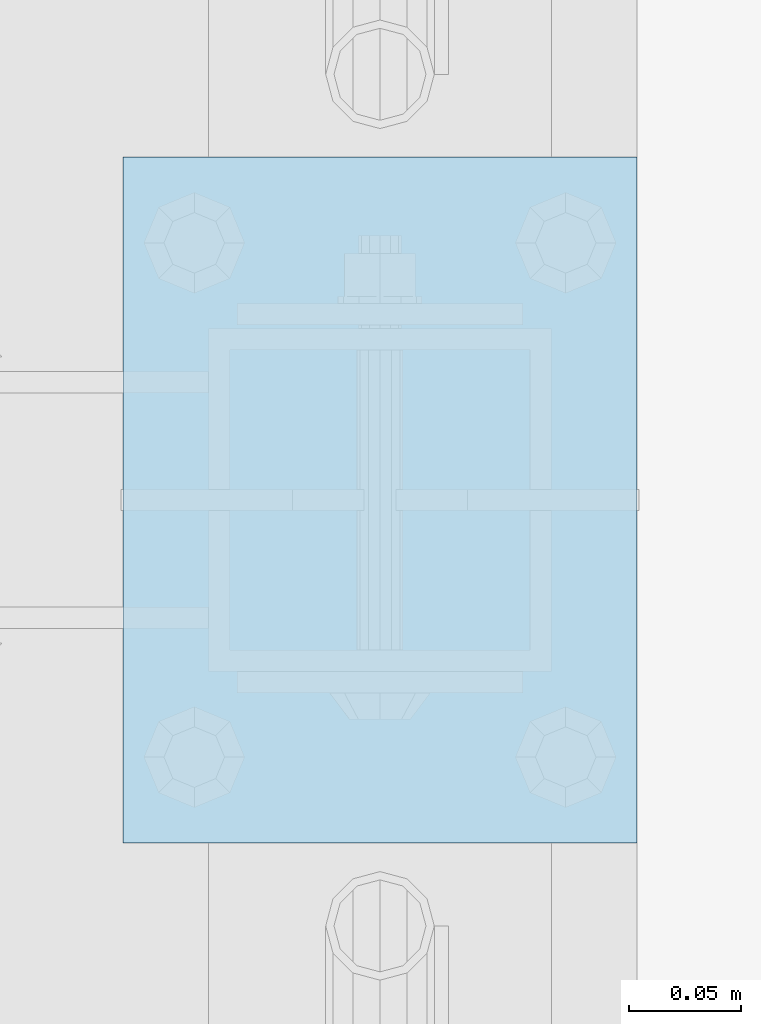
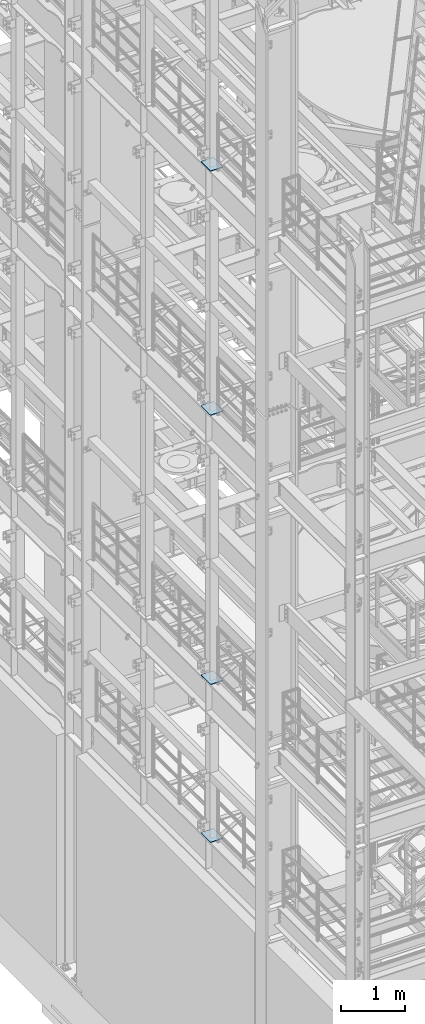
# One storey, part 1481 of 1876: 4 plates, 4 elements without a shape of their own.
"""IFC2X3 building model written with IfcOpenShell, lengths in millimetres."""

from ifc_helpers import new_model, si_unit, frame, origin_with_axes, place, context, subcontext, project, spatial, faceted_brep, material, type_object, element, aggregate, save


model = new_model("IFC2X3")

# Units and contexts
model_context = context("Model", 3, precision=1e-05, world=origin_with_axes())
body_context = subcontext(model_context, "Body", "Model", "MODEL_VIEW")
ifc_project = project(units=[si_unit("LENGTHUNIT", "METRE", prefix="MILLI"), si_unit("AREAUNIT", "SQUARE_METRE"), si_unit("VOLUMEUNIT", "CUBIC_METRE"), si_unit("MASSUNIT", "GRAM", prefix="KILO"), si_unit("TIMEUNIT", "SECOND"), si_unit("PLANEANGLEUNIT", "RADIAN"), si_unit("SOLIDANGLEUNIT", "STERADIAN"), si_unit("THERMODYNAMICTEMPERATUREUNIT", "DEGREE_CELSIUS"), si_unit("LUMINOUSINTENSITYUNIT", "LUMEN")], contexts=[model_context])

# Site, building, storey
site_placement = place(None, origin_with_axes())
site = spatial("IfcSite", under=ifc_project, at=site_placement, CompositionType="ELEMENT")
building_placement = place(site_placement, origin_with_axes())
building = spatial("IfcBuilding", under=site, at=building_placement, Name="Undefined", CompositionType="ELEMENT")
storey_placement = place(building_placement, origin_with_axes())
storey = spatial("IfcBuildingStorey", under=building, at=storey_placement, Name="Undefined", CompositionType="ELEMENT", Elevation=0.0)

# Assembly, plate
assembly_1_placement = place(storey_placement, origin_with_axes())
assembly_1 = element("IfcElementAssembly", 1, at=assembly_1_placement, inside=storey, Name="BEAM", AssemblyPlace="NOTDEFINED", PredefinedType="RIGID_FRAME")
ifc_material = material(Name="STEEL/A36")
plate_type = type_object("IfcPlateType", PredefinedType="NOTDEFINED")
plate_1_placement = place(assembly_1_placement, frame((-114.3, -2692.4, 17989.55), z_axis=(0.0, 1.0, 0.0), x_axis=(1.0, 0.0, 0.0)))
plate_1 = element("IfcPlate", 2, at=plate_1_placement, type_object=plate_type, material=ifc_material, Name="PLATE", context=body_context, shape_type="Brep", body=[
    faceted_brep([(0.0, -6.35000000000036, 0.0), (0.0, -6.35000000000036, 304.799987792969), (0.0, 6.35000000000036, 304.799987792969), (0.0, 6.35000000000036, 0.0), (228.600006103516, -6.34999999999854, 304.799987792969), (228.600006103516, 6.34999999999854, 304.799987792969), (228.600006103516, -6.34999999999854, 0.0), (228.600006103516, 6.34999999999854, 0.0)], [[[0, 1, 2, 3]], [[1, 4, 5, 2]], [[4, 6, 7, 5]], [[6, 0, 3, 7]], [[5, 7, 3, 2]], [[6, 4, 1, 0]]]),
])
aggregate(assembly_1, [plate_1])

assembly_2_placement = place(storey_placement, origin_with_axes())
assembly_2 = element("IfcElementAssembly", 3, at=assembly_2_placement, inside=storey, Name="BEAM", AssemblyPlace="NOTDEFINED", PredefinedType="RIGID_FRAME")
plate_2_placement = place(assembly_2_placement, frame((-114.3, -2692.4, 13315.95), z_axis=(0.0, 1.0, 0.0), x_axis=(1.0, 0.0, 0.0)))
plate_2 = element("IfcPlate", 4, at=plate_2_placement, type_object=plate_type, material=ifc_material, Name="PLATE", context=body_context, shape_type="Brep", body=[
    faceted_brep([(0.0, -6.35000000000036, 0.0), (0.0, -6.35000000000036, 304.799987792969), (0.0, 6.35000000000036, 304.799987792969), (0.0, 6.35000000000036, 0.0), (228.600006103516, -6.34999999999854, 304.799987792969), (228.600006103516, 6.34999999999854, 304.799987792969), (228.600006103516, -6.34999999999854, 0.0), (228.600006103516, 6.34999999999854, 0.0)], [[[0, 1, 2, 3]], [[1, 4, 5, 2]], [[4, 6, 7, 5]], [[6, 0, 3, 7]], [[5, 7, 3, 2]], [[6, 4, 1, 0]]]),
])
aggregate(assembly_2, [plate_2])

assembly_3_placement = place(storey_placement, origin_with_axes())
assembly_3 = element("IfcElementAssembly", 5, at=assembly_3_placement, inside=storey, Name="BEAM", AssemblyPlace="NOTDEFINED", PredefinedType="RIGID_FRAME")
plate_3_placement = place(assembly_3_placement, frame((-114.3, -2692.4, 8159.75), z_axis=(0.0, 1.0, 0.0), x_axis=(1.0, 0.0, 0.0)))
plate_3 = element("IfcPlate", 6, at=plate_3_placement, type_object=plate_type, material=ifc_material, Name="PLATE", context=body_context, shape_type="Brep", body=[
    faceted_brep([(0.0, -6.35000000000036, 0.0), (0.0, -6.35000000000036, 304.799987792969), (0.0, 6.35000000000036, 304.799987792969), (0.0, 6.35000000000036, 0.0), (228.600006103516, -6.34999999999854, 304.799987792969), (228.600006103516, 6.34999999999854, 304.799987792969), (228.600006103516, -6.34999999999854, 0.0), (228.600006103516, 6.34999999999854, 0.0)], [[[0, 1, 2, 3]], [[1, 4, 5, 2]], [[4, 6, 7, 5]], [[6, 0, 3, 7]], [[5, 7, 3, 2]], [[6, 4, 1, 0]]]),
])
aggregate(assembly_3, [plate_3])

assembly_4_placement = place(storey_placement, origin_with_axes())
assembly_4 = element("IfcElementAssembly", 7, at=assembly_4_placement, inside=storey, Name="BEAM", AssemblyPlace="NOTDEFINED", PredefinedType="RIGID_FRAME")
plate_4_placement = place(assembly_4_placement, frame((-114.3, -2692.4, 5137.15), z_axis=(0.0, 1.0, 0.0), x_axis=(1.0, 0.0, 0.0)))
plate_4 = element("IfcPlate", 8, at=plate_4_placement, type_object=plate_type, material=ifc_material, Name="PLATE", context=body_context, shape_type="Brep", body=[
    faceted_brep([(0.0, -6.35000000000036, 0.0), (0.0, -6.35000000000036, 304.799987792969), (0.0, 6.35000000000036, 304.799987792969), (0.0, 6.35000000000036, 0.0), (228.600006103516, -6.34999999999854, 304.799987792969), (228.600006103516, 6.34999999999854, 304.799987792969), (228.600006103516, -6.34999999999854, 0.0), (228.600006103516, 6.34999999999854, 0.0)], [[[0, 1, 2, 3]], [[1, 4, 5, 2]], [[4, 6, 7, 5]], [[6, 0, 3, 7]], [[5, 7, 3, 2]], [[6, 4, 1, 0]]]),
])
aggregate(assembly_4, [plate_4])

save(model, "model.ifc")
